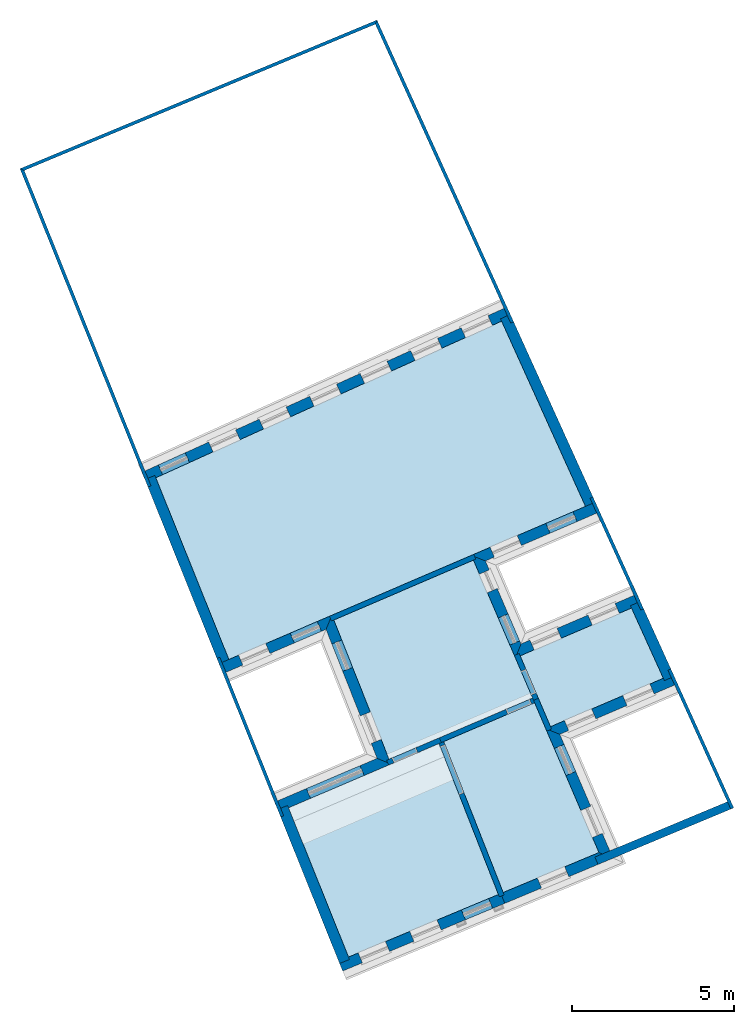
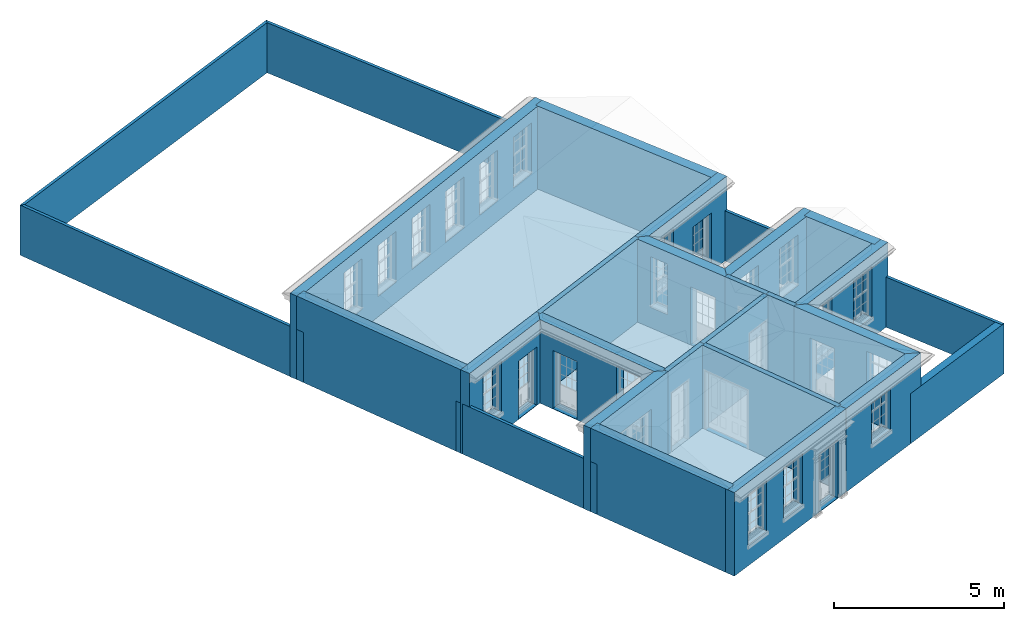
# One storey, part 1 of 19: 28 walls, 10 slabs, 30 openings.
"""IFC2X3 building model written with IfcOpenShell, lengths in metres."""

import ifcopenshell
import ifcopenshell.guid

model = None  # the IFC model being written
_history = None  # IfcOwnerHistory: only IFC2X3 demands one
_inside = {}  # id of a spatial element -> (the spatial element, [elements in it])
_under = {}  # id of a project, library or spatial element -> (it, [spatial elements below it])
_declared = {}  # id of a project -> (the project, [libraries it declares])
_typed = {}  # id of a type object -> (the type object, [elements of that type])
_made_of = {}  # id of a material, layer set ... -> (it, [elements and type objects made of it])


def new_model(schema):
    """Start an empty IFC model of exactly this schema.

    Asked for "IFC4X3", IfcOpenShell would pick the latest addendum, in which some entities
    have other attributes; the version numbers below select the first issue.
    IFC2X3 requires an IfcOwnerHistory on every rooted entity: one is made here for all.
    """
    global model, _history
    if schema == "IFC4X3":
        model = ifcopenshell.file(schema_version=(4, 3, 0, 0))
    else:
        model = ifcopenshell.file(schema=schema)
    _inside.clear()
    _under.clear()
    _declared.clear()
    _typed.clear()
    _made_of.clear()
    _history = None
    if model.schema == "IFC2X3":
        org = make("IfcOrganization", Name="unknown")
        user = make(
            "IfcPersonAndOrganization",
            ThePerson=make("IfcPerson", FamilyName="unknown"),
            TheOrganization=org,
        )
        app = make(
            "IfcApplication",
            ApplicationDeveloper=org,
            Version="unknown",
            ApplicationFullName="unknown",
            ApplicationIdentifier="unknown",
        )
        _history = make(
            "IfcOwnerHistory",
            OwningUser=user,
            OwningApplication=app,
            ChangeAction="ADDED",
            CreationDate=0,
        )
    return model


def make(cls, **values):
    """One entity of the class cls with the attributes given. An attribute that is None is left unset."""
    return model.create_entity(
        cls, **{name: value for name, value in values.items() if value is not None}
    )


def rooted(cls, **values):
    """An entity with a GlobalId (a new one), such as an element, a storey or a relation."""
    return make(cls, GlobalId=ifcopenshell.guid.new(), OwnerHistory=_history, **values)


def si_unit(unit_type, name, prefix=None):
    """IfcSIUnit, for example si_unit("LENGTHUNIT", "METRE", prefix="MILLI")."""
    return make("IfcSIUnit", UnitType=unit_type, Prefix=prefix, Name=name)


def assignment(units):
    """IfcUnitAssignment: the units of a project."""
    return None if units is None else make("IfcUnitAssignment", Units=units)


def point(xyz):
    """IfcCartesianPoint."""
    return None if xyz is None else make("IfcCartesianPoint", Coordinates=xyz)


def direction(xyz):
    """IfcDirection."""
    return None if xyz is None else make("IfcDirection", DirectionRatios=xyz)


def frame(location, z_axis=None, x_axis=None):
    """IfcAxis2Placement3D, a coordinate frame: its origin and axes. An axis left out is left unset."""
    return make(
        "IfcAxis2Placement3D",
        Location=point(location),
        Axis=direction(z_axis),
        RefDirection=direction(x_axis),
    )


def origin():
    """The frame at (0, 0, 0) with its axes left unset."""
    return frame((0.0, 0.0, 0.0))


def place(relative_to, where):
    """IfcLocalPlacement: puts the frame where relative to a parent placement (None: the world)."""
    return make(
        "IfcLocalPlacement", PlacementRelTo=relative_to, RelativePlacement=where
    )


def context(
    kind, dimensions, precision=None, world=None, true_north=None, identifier=None
):
    """IfcGeometricRepresentationContext, for example the 3D "Model" context."""
    return make(
        "IfcGeometricRepresentationContext",
        ContextIdentifier=identifier,
        ContextType=kind,
        CoordinateSpaceDimension=dimensions,
        Precision=precision,
        WorldCoordinateSystem=world,
        TrueNorth=true_north,
    )


def subcontext(parent, identifier, kind, view, scale=None):
    """IfcGeometricRepresentationSubContext, for example "Body" below "Model"."""
    return make(
        "IfcGeometricRepresentationSubContext",
        ContextIdentifier=identifier,
        ContextType=kind,
        ParentContext=parent,
        TargetScale=scale,
        TargetView=view,
    )


def project(units=None, contexts=None):
    """IfcProject with its units and contexts."""
    return rooted(
        "IfcProject",
        Name="project",
        RepresentationContexts=contexts,
        UnitsInContext=assignment(units),
    )


def spatial(cls, under=None, at=None, **own):
    """A site, building, storey or space (cls), placed at a placement, below another one or the project."""
    s = rooted(cls, ObjectPlacement=at, **own)
    if under is not None:
        _under.setdefault(under.id(), (under, []))[1].append(s)
    return s


def polyline(points):
    """IfcPolyline through the points."""
    return make("IfcPolyline", Points=[point(p) for p in points])


def outline(outer, holes=None, kind="AREA"):
    """IfcArbitraryClosedProfileDef: a profile drawn as a closed curve; with holes, ...WithVoids."""
    if holes is None:
        return make("IfcArbitraryClosedProfileDef", ProfileType=kind, OuterCurve=outer)
    return make(
        "IfcArbitraryProfileDefWithVoids",
        ProfileType=kind,
        OuterCurve=outer,
        InnerCurves=holes,
    )


def extrude(swept, where, along, depth):
    """IfcExtrudedAreaSolid: the profile swept, set in the frame where, extruded along a direction by depth."""
    return make(
        "IfcExtrudedAreaSolid",
        SweptArea=swept,
        Position=where,
        ExtrudedDirection=direction(along),
        Depth=depth,
    )


def shape(context_of_items, identifier, shape_type, items):
    """IfcShapeRepresentation: the items that make up one representation, for example the "Body"."""
    return make(
        "IfcShapeRepresentation",
        ContextOfItems=context_of_items,
        RepresentationIdentifier=identifier,
        RepresentationType=shape_type,
        Items=items,
    )


def material(Name=None, Category=None):
    """IfcMaterial."""
    return make("IfcMaterial", Name=Name, Category=Category)


def layer(
    of_material, thickness, ventilated=None, Name=None, Category=None, Priority=None
):
    """IfcMaterialLayer: one layer of a wall or slab, of a material (None: an air gap)."""
    return make(
        "IfcMaterialLayer",
        Material=of_material,
        LayerThickness=thickness,
        IsVentilated=ventilated,
        Name=Name,
        Category=Category,
        Priority=Priority,
    )


def layer_set(layers, Name=None):
    """IfcMaterialLayerSet."""
    return make("IfcMaterialLayerSet", MaterialLayers=layers, LayerSetName=Name)


def layer_usage(for_layer_set, set_direction, sense, offset, extent=None):
    """IfcMaterialLayerSetUsage: how a layer set lies in its element."""
    return make(
        "IfcMaterialLayerSetUsage",
        ForLayerSet=for_layer_set,
        LayerSetDirection=set_direction,
        DirectionSense=sense,
        OffsetFromReferenceLine=offset,
        ReferenceExtent=extent,
    )


def made_of(thing, what):
    """Note that an element or type object is made of a material, layer set ...; save() writes the relation."""
    if what is not None:
        _made_of.setdefault(what.id(), (what, []))[1].append(thing)
    return thing


def element(
    cls,
    number,
    at=None,
    inside=None,
    cuts=None,
    type_object=None,
    material=None,
    context=None,
    identifier="Body",
    shape_type=None,
    held_by="IfcProductDefinitionShape",
    body=None,
    shapes=None,
    **own,
):
    """One element of the class cls, such as IfcWall. Its Tag is "e" and its number.

    at: its placement. inside: the storey or other place that contains it. cuts: it is an
    opening in that element (IfcRelVoidsElement). A single representation is given by context,
    identifier, shape_type and body (its items); several are given by shapes. held_by: the class
    of the entity that holds the representations. save() writes the other relations.
    """
    e = rooted(cls, Tag="e%d" % number, ObjectPlacement=at, **own)
    if body is not None:
        shapes = [shape(context, identifier, shape_type, body)]
    if shapes is not None:
        e.Representation = make(held_by, Representations=shapes)
    if inside is not None:
        _inside.setdefault(inside.id(), (inside, []))[1].append(e)
    if cuts is not None:
        rooted(
            "IfcRelVoidsElement", RelatingBuildingElement=cuts, RelatedOpeningElement=e
        )
    if type_object is not None:
        _typed.setdefault(type_object.id(), (type_object, []))[1].append(e)
    return made_of(e, material)


def aggregate(whole, parts):
    """IfcRelAggregates: a whole, such as a stair, and the parts it consists of."""
    return rooted("IfcRelAggregates", RelatingObject=whole, RelatedObjects=parts)


def save(model, path):
    """Write the relations noted so far, then the file.

    IfcRelAggregates (storeys below a building ...), IfcRelContainedInSpatialStructure (elements
    in a storey), IfcRelDefinesByType, IfcRelAssociatesMaterial and IfcRelDeclares: one each for
    every whole, place, type object, material and project.
    """
    for whole, parts in _under.values():
        aggregate(whole, parts)
    for where, things in _inside.values():
        rooted(
            "IfcRelContainedInSpatialStructure",
            RelatedElements=things,
            RelatingStructure=where,
        )
    for kind, things in _typed.values():
        rooted("IfcRelDefinesByType", RelatedObjects=things, RelatingType=kind)
    for what, things in _made_of.values():
        rooted("IfcRelAssociatesMaterial", RelatedObjects=things, RelatingMaterial=what)
    for by, libraries in _declared.values():
        rooted("IfcRelDeclares", RelatingContext=by, RelatedDefinitions=libraries)
    model.write(path)


model = new_model("IFC2X3")

# Units and contexts
model_context = context("Model", 3, world=origin())
body_context = subcontext(model_context, "Body", "Model", "MODEL_VIEW")
ifc_project = project(units=[si_unit("PLANEANGLEUNIT", "RADIAN"), si_unit("MASSUNIT", "GRAM", prefix="KILO"), si_unit("FORCEUNIT", "NEWTON", prefix="KILO"), si_unit("LENGTHUNIT", "METRE")], contexts=[model_context])

# Site, building, storey
site_placement = place(None, origin())
site = spatial("IfcSite", under=ifc_project, at=site_placement, CompositionType="ELEMENT")
building_placement = place(None, origin())
building = spatial("IfcBuilding", under=site, at=building_placement, Name="Building plot-0", CompositionType="ELEMENT")
storey_placement = place(None, origin())
storey = spatial("IfcBuildingStorey", under=building, at=storey_placement, Name="Floor 0", CompositionType="ELEMENT", Elevation=0.0)

# Slabs
slab_1_placement = place(storey_placement, frame((0.0, 0.0, 2.8)))
element("IfcSlab", 1, at=slab_1_placement, inside=storey, Name="Slab", ObjectType="Slab", PredefinedType="FLOOR", context=body_context, shape_type="SweptSolid", body=[
    extrude(outline(polyline([(21.7725261921513, 29.9243833412803), (22.7108283488995, 27.7387566802755), (26.1908034089942, 29.2327300850544), (25.209374062335, 31.3998419941896), (21.7725261921513, 29.9243833412803)])), origin(), (0.0, 0.0, 1.0), 0.2),
])
slab_2_placement = place(storey_placement, frame((0.0, 0.0, 2.8)))
element("IfcSlab", 2, at=slab_2_placement, inside=storey, Name="Slab", ObjectType="Slab", PredefinedType="FLOOR", context=body_context, shape_type="SweptSolid", body=[
    extrude(outline(polyline([(19.2673830612975, 27.2176349681171), (14.6237469085448, 25.2359349790015), (16.4755421411, 20.6307089468795), (21.1013133018128, 22.5608558663923), (19.2673830612975, 27.2176349681171)])), origin(), (0.0, 0.0, 1.0), 0.2),
])
slab_3_placement = place(storey_placement, frame((0.0, 0.0, 2.8)))
element("IfcSlab", 3, at=slab_3_placement, inside=storey, Name="Slab", ObjectType="Slab", PredefinedType="FLOOR", context=body_context, shape_type="SweptSolid", body=[
    extrude(outline(polyline([(10.5286710747153, 35.4199712600771), (12.7832769783798, 29.8129961382087), (23.7883854008077, 34.5375527847061), (21.2001019503835, 40.2527883324566), (10.5286710747153, 35.4199712600771)])), origin(), (0.0, 0.0, 1.0), 0.2),
])
slab_4_placement = place(storey_placement, frame((0.0, 0.0, 2.8)))
element("IfcSlab", 4, at=slab_4_placement, inside=storey, Name="Slab", ObjectType="Slab", PredefinedType="FLOOR", context=body_context, shape_type="SweptSolid", body=[
    extrude(outline(polyline([(16.0225420074496, 31.0295102042354), (17.7255277771098, 26.7335994448823), (22.1564439529597, 28.6245198892519), (20.330074587468, 32.8787588349398), (16.0225420074496, 31.0295102042354)])), origin(), (0.0, 0.0, 1.0), 0.2),
])
slab_5_placement = place(storey_placement, frame((0.0, 0.0, 2.8)))
element("IfcSlab", 5, at=slab_5_placement, inside=storey, Name="Slab", ObjectType="Slab", PredefinedType="FLOOR", context=body_context, shape_type="SweptSolid", body=[
    extrude(outline(polyline([(22.2195623888506, 28.4774954629603), (19.4146013100445, 27.2804612517324), (21.2490044323092, 22.6224813923128), (24.203847145214, 23.8554175583724), (22.2195623888506, 28.4774954629603)])), origin(), (0.0, 0.0, 1.0), 0.2),
])
slab_6_placement = place(storey_placement, origin())
element("IfcSlab", 6, at=slab_6_placement, inside=storey, Name="Slab", ObjectType="Slab", PredefinedType="FLOOR", context=body_context, shape_type="SweptSolid", body=[
    extrude(outline(polyline([(19.2673830612975, 27.2176349681171), (14.6237469085448, 25.2359349790015), (16.4755421411, 20.6307089468795), (21.1013133018128, 22.5608558663923), (19.2673830612975, 27.2176349681171)])), origin(), (0.0, 0.0, 1.0), 0.02),
])
slab_7_placement = place(storey_placement, origin())
element("IfcSlab", 7, at=slab_7_placement, inside=storey, Name="Slab", ObjectType="Slab", PredefinedType="FLOOR", context=body_context, shape_type="SweptSolid", body=[
    extrude(outline(polyline([(10.5286710747153, 35.4199712600771), (12.7832769783798, 29.8129961382087), (23.7883854008077, 34.5375527847061), (21.2001019503835, 40.2527883324566), (10.5286710747153, 35.4199712600771)])), origin(), (0.0, 0.0, 1.0), 0.02),
])
slab_8_placement = place(storey_placement, origin())
element("IfcSlab", 8, at=slab_8_placement, inside=storey, Name="Slab", ObjectType="Slab", PredefinedType="FLOOR", context=body_context, shape_type="SweptSolid", body=[
    extrude(outline(polyline([(16.0225420074496, 31.0295102042354), (17.7255277771098, 26.7335994448823), (22.1564439529597, 28.6245198892519), (20.330074587468, 32.8787588349398), (16.0225420074496, 31.0295102042354)])), origin(), (0.0, 0.0, 1.0), 0.02),
])
slab_9_placement = place(storey_placement, origin())
element("IfcSlab", 9, at=slab_9_placement, inside=storey, Name="Slab", ObjectType="Slab", PredefinedType="FLOOR", context=body_context, shape_type="SweptSolid", body=[
    extrude(outline(polyline([(21.7725261921513, 29.9243833412803), (22.7108283488995, 27.7387566802755), (26.1908034089942, 29.2327300850544), (25.209374062335, 31.3998419941896), (21.7725261921513, 29.9243833412803)])), origin(), (0.0, 0.0, 1.0), 0.02),
])
slab_10_placement = place(storey_placement, origin())
element("IfcSlab", 10, at=slab_10_placement, inside=storey, Name="Slab", ObjectType="Slab", PredefinedType="FLOOR", context=body_context, shape_type="SweptSolid", body=[
    extrude(outline(polyline([(22.2195623888506, 28.4774954629603), (19.4146013100445, 27.2804612517324), (21.2490044323092, 22.6224813923128), (24.203847145214, 23.8554175583724), (22.2195623888506, 28.4774954629603)])), origin(), (0.0, 0.0, 1.0), 0.02),
])

# Wall, openings
ifc_material_1 = material(Name="Masonry")
ifc_layer_1 = layer(ifc_material_1, 0.33, ventilated=False)
ifc_layer_set_1 = layer_set([ifc_layer_1], Name="My Wall")
ifc_layer_usage_1 = layer_usage(ifc_layer_set_1, "AXIS2", "NEGATIVE", 0.08)
wall_1_placement = place(storey_placement, origin())
wall_1 = element("IfcWallStandardCase", 11, at=wall_1_placement, inside=storey, material=ifc_layer_usage_1, Name="exterior", context=body_context, shape_type="SweptSolid", body=[
    extrude(outline(polyline([(21.5007118437475, 40.3889268355029), (21.3645733407012, 40.6895367288669), (10.0949852202286, 35.5858295970064), (10.2311237232749, 35.2852197036424), (21.5007118437475, 40.3889268355029)])), origin(), (0.0, 0.0, 1.0), 3.0),
])
opening_1_placement = place(storey_placement, frame((0.0, 0.0, 0.75)))
element("IfcOpeningElement", 12, at=opening_1_placement, cuts=wall_1, Name="Opening", ObjectType="Opening", context=body_context, shape_type="SweptSolid", body=[
    extrude(outline(polyline([(20.7788788084242, 40.4242907119302), (19.9499242539963, 40.048878476257), (20.0860627570426, 39.748268582893), (20.9150173114706, 40.1236808185662), (20.7788788084242, 40.4242907119302)])), origin(), (0.0, 0.0, 1.0), 1.82),
])
opening_2_placement = place(storey_placement, frame((0.0, 0.0, 0.75)))
element("IfcOpeningElement", 13, at=opening_2_placement, cuts=wall_1, Name="Opening", ObjectType="Opening", context=body_context, shape_type="SweptSolid", body=[
    extrude(outline(polyline([(19.2211729973563, 39.7188457415993), (18.3922184429283, 39.3434335059261), (18.5283569459746, 39.0428236125621), (19.3573115004026, 39.4182358482353), (19.2211729973563, 39.7188457415993)])), origin(), (0.0, 0.0, 1.0), 1.82),
])
opening_3_placement = place(storey_placement, frame((0.0, 0.0, 0.75)))
element("IfcOpeningElement", 14, at=opening_3_placement, cuts=wall_1, Name="Opening", ObjectType="Opening", context=body_context, shape_type="SweptSolid", body=[
    extrude(outline(polyline([(17.6634671862884, 39.0134007712684), (16.8345126318604, 38.6379885355952), (16.9706511349067, 38.3373786422312), (17.7996056893347, 38.7127908779044), (17.6634671862884, 39.0134007712684)])), origin(), (0.0, 0.0, 1.0), 1.82),
])
opening_4_placement = place(storey_placement, frame((0.0, 0.0, 0.75)))
element("IfcOpeningElement", 15, at=opening_4_placement, cuts=wall_1, Name="Opening", ObjectType="Opening", context=body_context, shape_type="SweptSolid", body=[
    extrude(outline(polyline([(16.1057613752204, 38.3079558009375), (15.2768068207924, 37.9325435652643), (15.4129453238388, 37.6319336719003), (16.2418998782667, 38.0073459075735), (16.1057613752204, 38.3079558009375)])), origin(), (0.0, 0.0, 1.0), 1.82),
])
opening_5_placement = place(storey_placement, frame((0.0, 0.0, 0.75)))
element("IfcOpeningElement", 16, at=opening_5_placement, cuts=wall_1, Name="Opening", ObjectType="Opening", context=body_context, shape_type="SweptSolid", body=[
    extrude(outline(polyline([(14.5480555641525, 37.6025108306066), (13.7191010097245, 37.2270985949334), (13.8552395127708, 36.9264887015694), (14.6841940671988, 37.3019009372426), (14.5480555641525, 37.6025108306066)])), origin(), (0.0, 0.0, 1.0), 1.82),
])
opening_6_placement = place(storey_placement, frame((0.0, 0.0, 0.75)))
element("IfcOpeningElement", 17, at=opening_6_placement, cuts=wall_1, Name="Opening", ObjectType="Opening", context=body_context, shape_type="SweptSolid", body=[
    extrude(outline(polyline([(12.9903497530845, 36.8970658602757), (12.1613951986565, 36.5216536246025), (12.2975337017029, 36.2210437312385), (13.1264882561308, 36.5964559669117), (12.9903497530845, 36.8970658602757)])), origin(), (0.0, 0.0, 1.0), 1.82),
])
opening_7_placement = place(storey_placement, frame((0.0, 0.0, 0.02)))
element("IfcOpeningElement", 18, at=opening_7_placement, cuts=wall_1, Name="Opening", ObjectType="Opening", context=body_context, shape_type="SweptSolid", body=[
    extrude(outline(polyline([(11.4326439420166, 36.1916208899448), (10.6036893875886, 35.8162086542716), (10.7398278906349, 35.5155987609077), (11.5687824450629, 35.8910109965808), (11.4326439420166, 36.1916208899448)])), origin(), (0.0, 0.0, 1.0), 2.08),
])

wall_2_placement = place(storey_placement, origin())
wall_2 = element("IfcWallStandardCase", 19, at=wall_2_placement, inside=storey, material=ifc_layer_usage_1, Name="exterior", context=body_context, shape_type="SweptSolid", body=[
    extrude(outline(polyline([(12.4783149609257, 29.6820741816785), (12.6084964326969, 29.3788370065046), (15.7818582558488, 30.741179576684), (15.9635555189143, 31.1783080951337), (12.4783149609257, 29.6820741816785)])), origin(), (0.0, 0.0, 1.0), 3.0),
])
opening_8_placement = place(storey_placement, frame((0.0, 0.0, 0.75)))
element("IfcOpeningElement", 20, at=opening_8_placement, cuts=wall_2, Name="Opening", ObjectType="Opening", context=body_context, shape_type="SweptSolid", body=[
    extrude(outline(polyline([(13.2150989386918, 29.6392549680068), (14.0512984217472, 29.9982402386486), (13.921116949976, 30.3014774138226), (13.0849174669206, 29.9424921431808), (13.2150989386918, 29.6392549680068)])), origin(), (0.0, 0.0, 1.0), 1.82),
])
opening_9_placement = place(storey_placement, frame((0.0, 0.0, 0.02)))
element("IfcOpeningElement", 21, at=opening_9_placement, cuts=wall_2, Name="Opening", ObjectType="Opening", context=body_context, shape_type="SweptSolid", body=[
    extrude(outline(polyline([(14.8050531683218, 30.3218315074543), (15.6412526513772, 30.6808167780961), (15.511071179606, 30.9840539532701), (14.6748716965506, 30.6250686826283), (14.8050531683218, 30.3218315074543)])), origin(), (0.0, 0.0, 1.0), 2.08),
])

wall_3_placement = place(storey_placement, origin())
wall_3 = element("IfcWallStandardCase", 22, at=wall_3_placement, inside=storey, material=ifc_layer_usage_1, Name="exterior", context=body_context, shape_type="SweptSolid", body=[
    extrude(outline(polyline([(15.9635555189143, 31.1783080951337), (15.7818582558488, 30.741179576684), (17.3592391354437, 26.7621166784652), (17.784510830655, 26.584810219007), (15.9635555189143, 31.1783080951337)])), origin(), (0.0, 0.0, 1.0), 3.0),
])
opening_10_placement = place(storey_placement, frame((0.0, 0.0, 0.02)))
element("IfcOpeningElement", 23, at=opening_10_placement, cuts=wall_3, Name="Opening", ObjectType="Opening", context=body_context, shape_type="SweptSolid", body=[
    extrude(outline(polyline([(15.9599028628528, 30.2920485525146), (16.2952561162138, 29.446094537535), (16.6020306491185, 29.5677061568856), (16.2666773957576, 30.4136601718653), (15.9599028628528, 30.2920485525146)])), origin(), (0.0, 0.0, 1.0), 2.08),
])
opening_11_placement = place(storey_placement, frame((0.0, 0.0, 0.75)))
element("IfcOpeningElement", 24, at=opening_11_placement, cuts=wall_3, Name="Opening", ObjectType="Opening", context=body_context, shape_type="SweptSolid", body=[
    extrude(outline(polyline([(16.8408563451297, 28.0697765814704), (17.1762095984907, 27.2238225664908), (17.4829841313954, 27.3454341858414), (17.1476308780345, 28.1913882008211), (16.8408563451297, 28.0697765814704)])), origin(), (0.0, 0.0, 1.0), 1.82),
])

# Wall, opening
wall_4_placement = place(storey_placement, origin())
wall_4 = element("IfcWallStandardCase", 25, at=wall_4_placement, inside=storey, material=ifc_layer_usage_1, Name="exterior", context=body_context, shape_type="SweptSolid", body=[
    extrude(outline(polyline([(17.784510830655, 26.584810219007), (17.3592391354437, 26.7621166784652), (14.1922339119998, 25.4105779251313), (14.3217616381447, 25.1070609269916), (17.784510830655, 26.584810219007)])), origin(), (0.0, 0.0, 1.0), 3.0),
])
opening_12_placement = place(storey_placement, frame((0.0, 0.0, 0.02)))
element("IfcOpeningElement", 26, at=opening_12_placement, cuts=wall_4, Name="Opening", ObjectType="Opening", context=body_context, shape_type="SweptSolid", body=[
    extrude(outline(polyline([(16.8305029456204, 26.5364752915971), (15.17495568304, 25.8299604217163), (15.3044834091848, 25.5264434235766), (16.9600306717652, 26.2329582934574), (16.8305029456204, 26.5364752915971)])), origin(), (0.0, 0.0, 1.0), 2.08),
])

# Wall, openings
wall_5_placement = place(storey_placement, origin())
wall_5 = element("IfcWallStandardCase", 27, at=wall_5_placement, inside=storey, material=ifc_layer_usage_1, Name="exterior", context=body_context, shape_type="SweptSolid", body=[
    extrude(outline(polyline([(25.5111749941771, 31.5294068783981), (25.3809935224059, 31.832644053572), (21.7985578106213, 30.2946836988818), (21.6255021072185, 29.8612650519367), (25.5111749941771, 31.5294068783981)])), origin(), (0.0, 0.0, 1.0), 3.0),
])
opening_13_placement = place(storey_placement, frame((0.0, 0.0, 0.75)))
element("IfcOpeningElement", 28, at=opening_13_placement, cuts=wall_5, Name="Opening", ObjectType="Opening", context=body_context, shape_type="SweptSolid", body=[
    extrude(outline(polyline([(24.7016453088181, 31.540995939388), (23.8654458257626, 31.1820106687462), (23.9956272975338, 30.8787734935722), (24.8318267805893, 31.237758764214), (24.7016453088181, 31.540995939388)])), origin(), (0.0, 0.0, 1.0), 1.82),
])
opening_14_placement = place(storey_placement, frame((0.0, 0.0, 0.75)))
element("IfcOpeningElement", 29, at=opening_14_placement, cuts=wall_5, Name="Opening", ObjectType="Opening", context=body_context, shape_type="SweptSolid", body=[
    extrude(outline(polyline([(22.9104274529258, 30.7720157620429), (22.0742279698703, 30.4130304914011), (22.2044094416415, 30.1097933162271), (23.040608924697, 30.4687785868689), (22.9104274529258, 30.7720157620429)])), origin(), (0.0, 0.0, 1.0), 1.82),
])

wall_6_placement = place(storey_placement, origin())
wall_6 = element("IfcWallStandardCase", 30, at=wall_6_placement, inside=storey, material=ifc_layer_usage_1, Name="exterior", context=body_context, shape_type="SweptSolid", body=[
    extrude(outline(polyline([(21.6255021072185, 29.8612650519367), (21.7985578106213, 30.2946836988818), (20.7003749450695, 32.8527272164698), (20.2669562981244, 33.0257829198726), (21.6255021072185, 29.8612650519367)])), origin(), (0.0, 0.0, 1.0), 3.0),
])
opening_15_placement = place(storey_placement, frame((0.0, 0.0, 0.02)))
element("IfcOpeningElement", 31, at=opening_15_placement, cuts=wall_6, Name="Opening", ObjectType="Opening", context=body_context, shape_type="SweptSolid", body=[
    extrude(outline(polyline([(21.7591088797815, 30.3865737519649), (21.4001236091397, 31.2227732350203), (21.0968864339658, 31.0925917632491), (21.4558717046075, 30.2563922801937), (21.7591088797815, 30.3865737519649)])), origin(), (0.0, 0.0, 1.0), 2.08),
])
opening_16_placement = place(storey_placement, frame((0.0, 0.0, 0.75)))
element("IfcOpeningElement", 32, at=opening_16_placement, cuts=wall_6, Name="Opening", ObjectType="Opening", context=body_context, shape_type="SweptSolid", body=[
    extrude(outline(polyline([(21.0652775553373, 32.0027442254519), (20.8187217375888, 32.5770570572208), (20.5154845624148, 32.4468755854496), (20.7620403801633, 31.8725627536807), (21.0652775553373, 32.0027442254519)])), origin(), (0.0, 0.0, 1.0), 1.82),
])

wall_7_placement = place(storey_placement, origin())
wall_7 = element("IfcWallStandardCase", 33, at=wall_7_placement, inside=storey, material=ifc_layer_usage_1, Name="exterior", context=body_context, shape_type="SweptSolid", body=[
    extrude(outline(polyline([(20.2669562981244, 33.0257829198726), (20.7003749450695, 32.8527272164698), (24.2232689108841, 34.3651259555113), (24.0930874391129, 34.6683631306853), (20.2669562981244, 33.0257829198726)])), origin(), (0.0, 0.0, 1.0), 3.0),
])
opening_17_placement = place(storey_placement, frame((0.0, 0.0, 0.75)))
element("IfcOpeningElement", 34, at=opening_17_placement, cuts=wall_7, Name="Opening", ObjectType="Opening", context=body_context, shape_type="SweptSolid", body=[
    extrude(outline(polyline([(20.9760451043186, 32.9710740089891), (21.8122445873741, 33.3300592796309), (21.6820631156029, 33.6332964548049), (20.8458636325474, 33.2743111841631), (20.9760451043186, 32.9710740089891)])), origin(), (0.0, 0.0, 1.0), 1.82),
])
opening_18_placement = place(storey_placement, frame((0.0, 0.0, 0.02)))
element("IfcOpeningElement", 35, at=opening_18_placement, cuts=wall_7, Name="Opening", ObjectType="Opening", context=body_context, shape_type="SweptSolid", body=[
    extrude(outline(polyline([(22.6947205451952, 33.7089113083307), (23.5309200282507, 34.0678965789725), (23.4007385564795, 34.3711337541464), (22.564539073424, 34.0121484835047), (22.6947205451952, 33.7089113083307)])), origin(), (0.0, 0.0, 1.0), 2.08),
])

wall_8_placement = place(storey_placement, origin())
wall_8 = element("IfcWallStandardCase", 36, at=wall_8_placement, inside=storey, material=ifc_layer_usage_1, Name="exterior", context=body_context, shape_type="SweptSolid", body=[
    extrude(outline(polyline([(16.1700267177394, 20.5032297368677), (16.2971036159413, 20.1986784900415), (21.3007494176732, 22.2864971898878), (21.1736725194713, 22.591048436714), (16.1700267177394, 20.5032297368677)])), origin(), (0.0, 0.0, 1.0), 3.0),
])
opening_19_placement = place(storey_placement, frame((0.0, 0.0, 0.75)))
element("IfcOpeningElement", 37, at=opening_19_placement, cuts=wall_8, Name="Opening", ObjectType="Opening", context=body_context, shape_type="SweptSolid", body=[
    extrude(outline(polyline([(16.9034002165821, 20.4516615009559), (17.7432233517695, 20.8020856747854), (17.6161464535675, 21.1066369216116), (16.7763233183802, 20.756212747782), (16.9034002165821, 20.4516615009559)])), origin(), (0.0, 0.0, 1.0), 1.82),
])
opening_20_placement = place(storey_placement, frame((0.0, 0.0, 0.75)))
element("IfcOpeningElement", 38, at=opening_20_placement, cuts=wall_8, Name="Opening", ObjectType="Opening", context=body_context, shape_type="SweptSolid", body=[
    extrude(outline(polyline([(18.4943752699811, 21.1155109417627), (19.3341984051684, 21.4659351155923), (19.2071215069665, 21.7704863624185), (18.3672983717792, 21.4200621885889), (18.4943752699811, 21.1155109417627)])), origin(), (0.0, 0.0, 1.0), 1.82),
])
opening_21_placement = place(storey_placement, frame((0.0, 0.0, 0.02)))
element("IfcOpeningElement", 39, at=opening_21_placement, cuts=wall_8, Name="Opening", ObjectType="Opening", context=body_context, shape_type="SweptSolid", body=[
    extrude(outline(polyline([(20.0853503233801, 21.7793603825696), (20.9251734585674, 22.1297845563992), (20.7980965603655, 22.4343358032253), (19.9582734251781, 22.0839116293958), (20.0853503233801, 21.7793603825696)])), origin(), (0.0, 0.0, 1.0), 2.08),
])

# Wall, opening
wall_9_placement = place(storey_placement, origin())
wall_9 = element("IfcWallStandardCase", 40, at=wall_9_placement, inside=storey, material=ifc_layer_usage_1, Name="exterior", context=body_context, shape_type="SweptSolid", body=[
    extrude(outline(polyline([(21.1736725194713, 22.591048436714), (21.3007494176732, 22.2864971898878), (24.6386025500617, 23.6792480885884), (24.2038471452139, 23.8554175583724), (21.1736725194713, 22.591048436714)])), origin(), (0.0, 0.0, 1.0), 3.0),
])
opening_22_placement = place(storey_placement, frame((0.0, 0.0, 1.05)))
element("IfcOpeningElement", 41, at=opening_22_placement, cuts=wall_9, Name="Opening", ObjectType="Opening", context=body_context, shape_type="SweptSolid", body=[
    extrude(outline(polyline([(22.4332195273928, 22.7590310913225), (23.2730426625801, 23.1094552651521), (23.1459657643782, 23.4140065119782), (22.3061426291909, 23.0635823381487), (22.4332195273928, 22.7590310913225)])), origin(), (0.0, 0.0, 1.0), 1.445),
])

# Wall, openings
wall_10_placement = place(storey_placement, origin())
wall_10 = element("IfcWallStandardCase", 42, at=wall_10_placement, inside=storey, material=ifc_layer_usage_1, Name="exterior", context=body_context, shape_type="SweptSolid", body=[
    extrude(outline(polyline([(24.2038471452139, 23.8554175583724), (24.6386025500617, 23.6792480885884), (22.9972229109118, 27.5025826875291), (22.5638042639667, 27.6756383909319), (24.2038471452139, 23.8554175583724)])), origin(), (0.0, 0.0, 1.0), 3.0),
])
opening_23_placement = place(storey_placement, frame((0.0, 0.0, 1.05)))
element("IfcOpeningElement", 43, at=opening_23_placement, cuts=wall_10, Name="Opening", ObjectType="Opening", context=body_context, shape_type="SweptSolid", body=[
    extrude(outline(polyline([(24.3083684269602, 24.4484763149473), (23.9493831563184, 25.2846757980027), (23.6461459811444, 25.1544943262315), (24.0051312517862, 24.3182948431761), (24.3083684269602, 24.4484763149473)])), origin(), (0.0, 0.0, 1.0), 1.445),
])
opening_24_placement = place(storey_placement, frame((0.0, 0.0, 0.02)))
element("IfcOpeningElement", 44, at=opening_24_placement, cuts=wall_10, Name="Opening", ObjectType="Opening", context=body_context, shape_type="SweptSolid", body=[
    extrude(outline(polyline([(23.4881849550756, 26.3589641574551), (23.1291996844338, 27.1951636405105), (22.8259625092599, 27.0649821687393), (23.1849477799017, 26.2287826856839), (23.4881849550756, 26.3589641574551)])), origin(), (0.0, 0.0, 1.0), 2.08),
])

wall_11_placement = place(storey_placement, origin())
wall_11 = element("IfcWallStandardCase", 45, at=wall_11_placement, inside=storey, material=ifc_layer_usage_1, Name="exterior", context=body_context, shape_type="SweptSolid", body=[
    extrude(outline(polyline([(22.5638042639667, 27.6756383909319), (22.9972229109118, 27.5025826875291), (26.6256869190706, 29.0603032558596), (26.4955054472994, 29.3635404310336), (22.5638042639667, 27.6756383909319)])), origin(), (0.0, 0.0, 1.0), 3.0),
])
opening_25_placement = place(storey_placement, frame((0.0, 0.0, 0.75)))
element("IfcOpeningElement", 46, at=opening_25_placement, cuts=wall_11, Name="Opening", ObjectType="Opening", context=body_context, shape_type="SweptSolid", body=[
    extrude(outline(polyline([(23.2728930701609, 27.6209294800484), (24.1090925532164, 27.9799147506902), (23.9789110814452, 28.2831519258642), (23.1427115983897, 27.9241666552224), (23.2728930701609, 27.6209294800484)])), origin(), (0.0, 0.0, 1.0), 1.82),
])
opening_26_placement = place(storey_placement, frame((0.0, 0.0, 0.75)))
element("IfcOpeningElement", 47, at=opening_26_placement, cuts=wall_11, Name="Opening", ObjectType="Opening", context=body_context, shape_type="SweptSolid", body=[
    extrude(outline(polyline([(25.0707460427957, 28.3927581513567), (25.9069455258511, 28.7517434219985), (25.7767640540799, 29.0549805971725), (24.9405645710245, 28.6959953265307), (25.0707460427957, 28.3927581513567)])), origin(), (0.0, 0.0, 1.0), 1.82),
])

# Walls
wall_12_placement = place(storey_placement, origin())
element("IfcWallStandardCase", 48, at=wall_12_placement, inside=storey, material=ifc_layer_usage_1, Name="party", context=body_context, shape_type="SweptSolid", body=[
    extrude(outline(polyline([(26.2244643335997, 29.158402788002), (26.5250742269637, 29.2945412910483), (25.4776254844977, 31.6074318233456), (25.1770155911337, 31.4712933202993), (26.2244643335997, 29.158402788002)])), origin(), (0.0, 0.0, 1.0), 3.0),
])
wall_13_placement = place(storey_placement, origin())
element("IfcWallStandardCase", 49, at=wall_13_placement, inside=storey, material=ifc_layer_usage_1, Name="party", context=body_context, shape_type="SweptSolid", body=[
    extrude(outline(polyline([(23.8220463254132, 34.4632254876537), (24.1226562187772, 34.5993639907), (21.4677085702817, 40.4618019611669), (21.1670986769177, 40.3256634581206), (23.8220463254132, 34.4632254876537)])), origin(), (0.0, 0.0, 1.0), 3.0),
])
wall_14_placement = place(storey_placement, origin())
element("IfcWallStandardCase", 50, at=wall_14_placement, inside=storey, material=ifc_layer_usage_1, Name="party", context=body_context, shape_type="SweptSolid", body=[
    extrude(outline(polyline([(14.5945221733719, 25.3086139171658), (14.2883478586013, 25.1854989750395), (16.199603641588, 20.432400613452), (16.5057779563586, 20.5555155555783), (14.5945221733719, 25.3086139171658)])), origin(), (0.0, 0.0, 1.0), 3.0),
])
wall_15_placement = place(storey_placement, origin())
element("IfcWallStandardCase", 51, at=wall_15_placement, inside=storey, material=ifc_layer_usage_1, Name="party", context=body_context, shape_type="SweptSolid", body=[
    extrude(outline(polyline([(10.5000792938171, 35.491076105463), (10.1939049790465, 35.3679611633367), (12.5076489998425, 29.6139155707613), (12.8138233146131, 29.7370305128876), (10.5000792938171, 35.491076105463)])), origin(), (0.0, 0.0, 1.0), 3.0),
])
ifc_material_2 = material(Name="Masonry")
ifc_layer_2 = layer(ifc_material_2, 0.16, ventilated=False)
ifc_layer_set_2 = layer_set([ifc_layer_2], Name="My Wall")
ifc_layer_usage_2 = layer_usage(ifc_layer_set_2, "AXIS2", "NEGATIVE", 0.08)
wall_16_placement = place(storey_placement, origin())
element("IfcWallStandardCase", 52, at=wall_16_placement, inside=storey, material=ifc_layer_usage_2, Name="interior", context=body_context, shape_type="SweptSolid", body=[
    extrude(outline(polyline([(15.8879485528933, 31.1458495876729), (15.9510668422369, 30.9988255027401), (20.4035866299344, 32.9103179796116), (20.3404683405908, 33.0573420645444), (15.8879485528933, 31.1458495876729)])), origin(), (0.0, 0.0, 1.0), 3.0),
])

# Wall, opening
wall_17_placement = place(storey_placement, origin())
wall_17 = element("IfcWallStandardCase", 53, at=wall_17_placement, inside=storey, material=ifc_layer_usage_2, Name="interior", context=body_context, shape_type="SweptSolid", body=[
    extrude(outline(polyline([(22.2929838809625, 28.5088285315585), (22.2301825591953, 28.6559882882323), (19.2802656397847, 27.3970932898327), (19.3430669615519, 27.2499335331589), (22.2929838809625, 28.5088285315585)])), origin(), (0.0, 0.0, 1.0), 3.0),
])
opening_27_placement = place(storey_placement, frame((0.0, 0.0, 0.02)))
element("IfcOpeningElement", 54, at=opening_27_placement, cuts=wall_17, Name="Opening", ObjectType="Opening", context=body_context, shape_type="SweptSolid", body=[
    extrude(outline(polyline([(22.0646278329373, 28.5853368012442), (21.3288290495682, 28.2713301924083), (21.3916303713354, 28.1241704357345), (22.1274291547045, 28.4381770445704), (22.0646278329373, 28.5853368012442)])), origin(), (0.0, 0.0, 1.0), 2.1),
])

wall_18_placement = place(storey_placement, origin())
wall_18 = element("IfcWallStandardCase", 55, at=wall_18_placement, inside=storey, material=ifc_layer_usage_2, Name="interior", context=body_context, shape_type="SweptSolid", body=[
    extrude(outline(polyline([(21.7409670474795, 29.9978953837467), (21.5939429625467, 29.9347770944031), (22.1880711776125, 28.5508492652236), (22.3350952625453, 28.6139675545672), (21.7409670474795, 29.9978953837467)])), origin(), (0.0, 0.0, 1.0), 3.0),
])
opening_28_placement = place(storey_placement, frame((0.0, 0.0, 0.02)))
element("IfcOpeningElement", 56, at=opening_28_placement, cuts=wall_18, Name="Opening", ObjectType="Opening", context=body_context, shape_type="SweptSolid", body=[
    extrude(outline(polyline([(21.8014716553829, 29.4513717854372), (22.1170631021009, 28.716251360773), (22.2640871870338, 28.7793696501166), (21.9484957403157, 29.5144900747808), (21.8014716553829, 29.4513717854372)])), origin(), (0.0, 0.0, 1.0), 2.1),
])

wall_19_placement = place(storey_placement, origin())
wall_19 = element("IfcWallStandardCase", 57, at=wall_19_placement, inside=storey, material=ifc_layer_usage_2, Name="interior", context=body_context, shape_type="SweptSolid", body=[
    extrude(outline(polyline([(19.3430669615519, 27.2499335331589), (19.2802656397847, 27.3970932898327), (17.6500140012353, 26.701373481455), (17.7128153230025, 26.5542137247812), (19.3430669615519, 27.2499335331589)])), origin(), (0.0, 0.0, 1.0), 3.0),
])
opening_29_placement = place(storey_placement, frame((0.0, 0.0, 0.02)))
element("IfcOpeningElement", 58, at=opening_29_placement, cuts=wall_19, Name="Opening", ObjectType="Opening", context=body_context, shape_type="SweptSolid", body=[
    extrude(outline(polyline([(18.5513675108624, 27.086031577279), (17.8155687274933, 26.7720249684431), (17.8783700492605, 26.6248652117693), (18.6141688326296, 26.9388718206052), (18.5513675108624, 27.086031577279)])), origin(), (0.0, 0.0, 1.0), 2.1),
])

# Wall
wall_20_placement = place(storey_placement, origin())
element("IfcWallStandardCase", 59, at=wall_20_placement, inside=storey, material=ifc_layer_usage_2, Name="interior", context=body_context, shape_type="SweptSolid", body=[
    extrude(outline(polyline([(22.3350952625453, 28.6139675545672), (22.1880711776125, 28.5508492652236), (22.5953634086385, 27.6021263484655), (22.7423874935713, 27.6652446378091), (22.3350952625453, 28.6139675545672)])), origin(), (0.0, 0.0, 1.0), 3.0),
])

# Wall, opening
wall_21_placement = place(storey_placement, origin())
wall_21 = element("IfcWallStandardCase", 60, at=wall_21_placement, inside=storey, material=ifc_layer_usage_2, Name="interior", context=body_context, shape_type="SweptSolid", body=[
    extrude(outline(polyline([(19.3861020160304, 27.3528276448736), (19.2372305853062, 27.294199178118), (21.1300433248854, 22.487903598045), (21.2789147556096, 22.5465320648006), (19.3861020160304, 27.3528276448736)])), origin(), (0.0, 0.0, 1.0), 3.0),
])
opening_30_placement = place(storey_placement, frame((0.0, 0.0, 0.02)))
element("IfcOpeningElement", 61, at=opening_30_placement, cuts=wall_21, Name="Opening", ObjectType="Opening", context=body_context, shape_type="SweptSolid", body=[
    extrude(outline(polyline([(19.3031876104063, 27.1267188185532), (19.889472277963, 25.6380045113109), (20.0383437086872, 25.6966329780665), (19.4520590411305, 27.1853472853089), (19.3031876104063, 27.1267188185532)])), origin(), (0.0, 0.0, 1.0), 2.1),
])

# Walls
ifc_material_3 = material(Name="Masonry")
ifc_layer_3 = layer(ifc_material_3, 0.1, ventilated=False)
ifc_layer_set_3 = layer_set([ifc_layer_3], Name="My Wall")
ifc_layer_usage_3 = layer_usage(ifc_layer_set_3, "AXIS2", "NEGATIVE", -0.15)
wall_22_placement = place(storey_placement, origin())
element("IfcWallStandardCase", 62, at=wall_22_placement, inside=storey, material=ifc_layer_usage_3, Name="fence", context=body_context, shape_type="SweptSolid", body=[
    extrude(outline(polyline([(25.4896668069982, 31.3384429638134), (25.5807607140782, 31.3796970556456), (24.0195209891967, 34.8270987584), (23.9284270821167, 34.7858446665678), (25.4896668069982, 31.3384429638134)])), origin(), (0.0, 0.0, 1.0), 1.8),
])
wall_23_placement = place(storey_placement, origin())
element("IfcWallStandardCase", 63, at=wall_23_placement, inside=storey, material=ifc_layer_usage_3, Name="fence", context=body_context, shape_type="SweptSolid", body=[
    extrude(outline(polyline([(12.5071601996774, 29.883173367444), (12.4143801042923, 29.8458658092239), (14.3816167541515, 24.9535487365769), (14.4743968495366, 24.990856294797), (12.5071601996774, 29.883173367444)])), origin(), (0.0, 0.0, 1.0), 1.8),
])
wall_24_placement = place(storey_placement, origin())
element("IfcWallStandardCase", 64, at=wall_24_placement, inside=storey, material=ifc_layer_usage_3, Name="fence", context=body_context, shape_type="SweptSolid", body=[
    extrude(outline(polyline([(28.2698734931316, 25.1994182445236), (28.3609674002116, 25.2406723363558), (26.4219389973832, 29.5222760587483), (26.3308450903032, 29.4810219669161), (28.2698734931316, 25.1994182445236)])), origin(), (0.0, 0.0, 1.0), 1.8),
])
wall_25_placement = place(storey_placement, origin())
element("IfcWallStandardCase", 65, at=wall_25_placement, inside=storey, material=ifc_layer_usage_3, Name="fence", context=body_context, shape_type="SweptSolid", body=[
    extrude(outline(polyline([(21.4797498927822, 40.1928131016347), (21.5708437998622, 40.2340671934669), (17.3535057795591, 49.5464476309979), (17.3024270079802, 49.4168353939917), (21.4797498927822, 40.1928131016347)])), origin(), (0.0, 0.0, 1.0), 1.8),
])
wall_26_placement = place(storey_placement, origin())
element("IfcWallStandardCase", 66, at=wall_26_placement, inside=storey, material=ifc_layer_usage_3, Name="fence", context=body_context, shape_type="SweptSolid", body=[
    extrude(outline(polyline([(17.3024270079802, 49.4168353939917), (17.3535057795591, 49.5464476309979), (6.33802354213981, 44.9571453548934), (6.46765024381887, 44.9028191581943), (17.3024270079802, 49.4168353939917)])), origin(), (0.0, 0.0, 1.0), 1.8),
])
wall_27_placement = place(storey_placement, origin())
element("IfcWallStandardCase", 67, at=wall_27_placement, inside=storey, material=ifc_layer_usage_3, Name="fence", context=body_context, shape_type="SweptSolid", body=[
    extrude(outline(polyline([(6.46765024381887, 44.9028191581943), (6.33802354213981, 44.9571453548934), (10.2871738745967, 35.1360109248741), (10.3799539699818, 35.1733184830942), (6.46765024381887, 44.9028191581943)])), origin(), (0.0, 0.0, 1.0), 1.8),
])
ifc_material_4 = material(Name="Masonry")
ifc_layer_4 = layer(ifc_material_4, 0.25, ventilated=False)
ifc_layer_set_4 = layer_set([ifc_layer_4], Name="My Wall")
ifc_layer_usage_4 = layer_usage(ifc_layer_set_4, "AXIS2", "NEGATIVE", 0.0)
wall_28_placement = place(storey_placement, origin())
element("IfcWallStandardCase", 68, at=wall_28_placement, inside=storey, material=ifc_layer_usage_4, Name="fence", context=body_context, shape_type="SweptSolid", body=[
    extrude(outline(polyline([(24.078521753339, 23.716439430696), (24.1747921307647, 23.485718789161), (28.3570884218918, 25.230821610366), (28.2608180444661, 25.461542251901), (24.078521753339, 23.716439430696)])), origin(), (0.0, 0.0, 1.0), 1.8),
])

save(model, "model.ifc")
